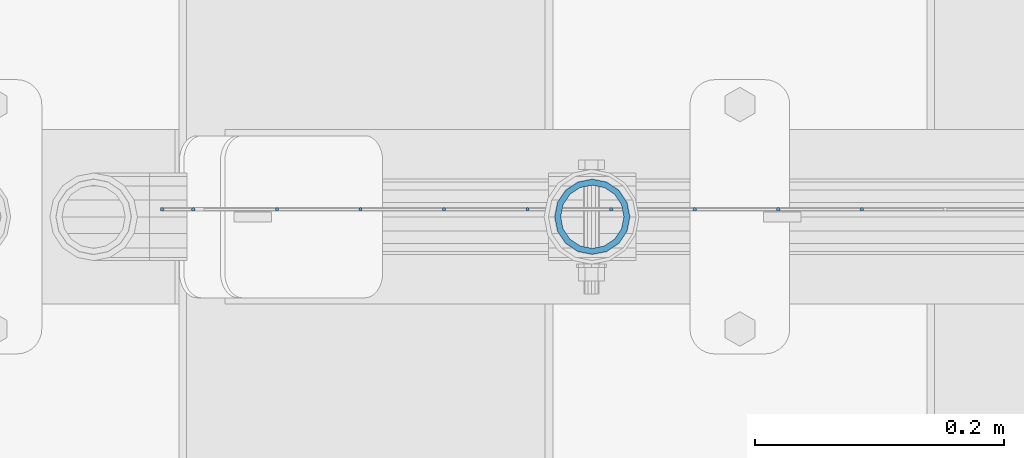
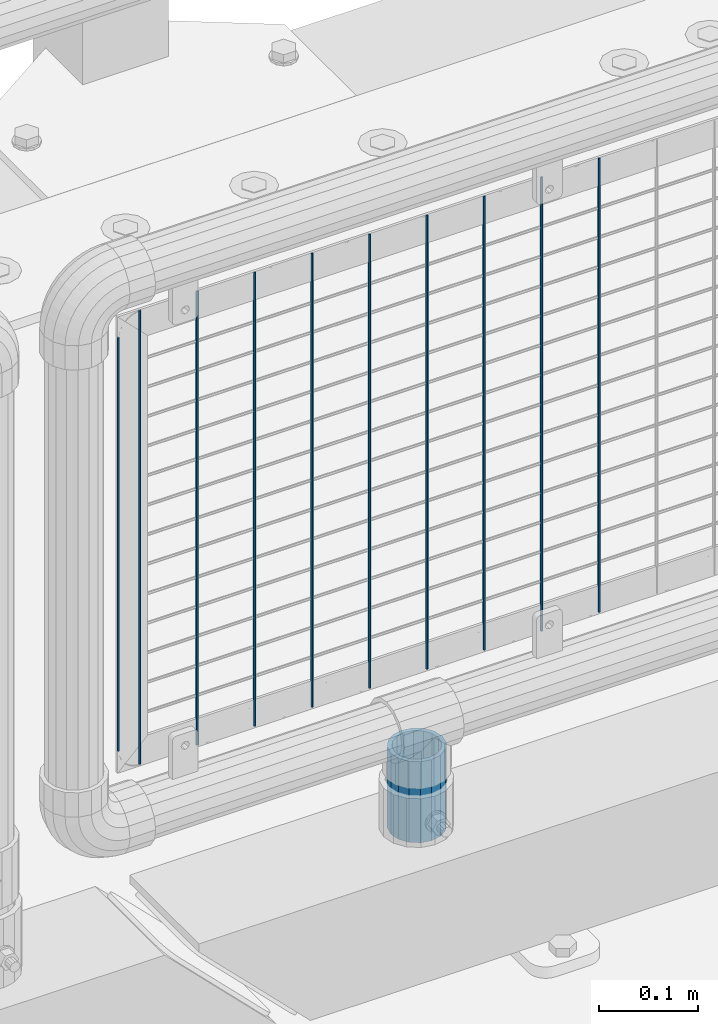
# One storey, part 94 of 240: 11 columns.
"""IFC2X3 building model written with IfcOpenShell, lengths in millimetres."""

from ifc_helpers import new_model, si_unit, frame, origin_with_axes, place, context, subcontext, project, spatial, faceted_brep, material, type_object, element, save


model = new_model("IFC2X3")

# Units and contexts
model_context = context("Model", 3, precision=1e-05, world=origin_with_axes())
body_context = subcontext(model_context, "Body", "Model", "MODEL_VIEW")
ifc_project = project(units=[si_unit("LENGTHUNIT", "METRE", prefix="MILLI"), si_unit("AREAUNIT", "SQUARE_METRE"), si_unit("VOLUMEUNIT", "CUBIC_METRE"), si_unit("MASSUNIT", "GRAM", prefix="KILO"), si_unit("TIMEUNIT", "SECOND"), si_unit("PLANEANGLEUNIT", "RADIAN"), si_unit("SOLIDANGLEUNIT", "STERADIAN"), si_unit("THERMODYNAMICTEMPERATUREUNIT", "DEGREE_CELSIUS"), si_unit("LUMINOUSINTENSITYUNIT", "LUMEN")], contexts=[model_context])

# Site, building, storey
site_placement = place(None, origin_with_axes())
site = spatial("IfcSite", under=ifc_project, at=site_placement, CompositionType="ELEMENT")
building_placement = place(site_placement, origin_with_axes())
building = spatial("IfcBuilding", under=site, at=building_placement, Name="Standard", CompositionType="ELEMENT")
storey_placement = place(building_placement, origin_with_axes())
storey = spatial("IfcBuildingStorey", under=building, at=storey_placement, Name="Undefined", CompositionType="ELEMENT", Elevation=0.0)

# Columns
ifc_material_1 = material()
column_type_1 = type_object("IfcColumnType", PredefinedType="NOTDEFINED")
column_1_placement = place(storey_placement, frame((55181.61, 34664.5, 168.02), z_axis=(-1.0, 0.0, 0.0), x_axis=(0.0, 0.0, 1.0)))
element("IfcColumn", 1, at=column_1_placement, inside=storey, type_object=column_type_1, material=ifc_material_1, context=body_context, shape_type="Brep", body=[
    faceted_brep([(0.0, -25.3499999999985, 0.0), (0.0, -23.4203461491634, 9.70102501045767), (100.0, -23.4203461491634, 9.70102501045767), (100.0, -25.3499999999985, 0.0), (0.0, -17.9251569030821, 17.9251569030821), (100.0, -17.9251569030821, 17.9251569030821), (0.0, -9.70102501045767, 23.4203461491634), (100.0, -9.70102501045767, 23.4203461491634), (0.0, 0.0, 25.3499999999985), (100.0, 0.0, 25.3499999999985), (0.0, 9.70102501045767, 23.4203461491634), (100.0, 9.70102501045767, 23.4203461491634), (0.0, 17.9251569030821, 17.9251569030821), (100.0, 17.9251569030821, 17.9251569030821), (0.0, 23.4203461491634, 9.70102501045767), (100.0, 23.4203461491634, 9.70102501045767), (0.0, 25.3499999999985, 0.0), (100.0, 25.3499999999985, 0.0), (0.0, 23.4203461491634, -9.70102501045767), (100.0, 23.4203461491634, -9.70102501045767), (0.0, 17.9251569030821, -17.9251569030821), (100.0, 17.9251569030821, -17.9251569030821), (0.0, 9.70102501045767, -23.4203461491634), (100.0, 9.70102501045767, -23.4203461491634), (0.0, 0.0, -25.3499999999985), (100.0, 0.0, -25.3499999999985), (0.0, -9.70102501045767, -23.4203461491634), (100.0, -9.70102501045767, -23.4203461491634), (0.0, -17.9251569030821, -17.9251569030821), (100.0, -17.9251569030821, -17.9251569030821), (0.0, -23.4203461491634, -9.70102501045767), (100.0, -23.4203461491634, -9.70102501045767), (0.0, -30.1500000000015, 0.0), (0.0, -27.8549679052157, -11.5379054858058), (100.0, -27.8549679052157, -11.5379054858058), (100.0, -30.1500000000015, 0.0), (0.0, -21.3192694527752, -21.3192694527752), (100.0, -21.3192694527752, -21.3192694527752), (0.0, -11.5379054858058, -27.8549679052157), (100.0, -11.5379054858058, -27.8549679052157), (0.0, 0.0, -30.1500000000015), (100.0, 0.0, -30.1500000000015), (0.0, 11.5379054858058, -27.8549679052157), (100.0, 11.5379054858058, -27.8549679052157), (0.0, 21.3192694527752, -21.3192694527752), (100.0, 21.3192694527752, -21.3192694527752), (0.0, 27.8549679052157, -11.5379054858058), (100.0, 27.8549679052157, -11.5379054858058), (0.0, 30.1500000000015, 0.0), (100.0, 30.1500000000015, 0.0), (0.0, 27.8549679052157, 11.5379054858058), (100.0, 27.8549679052157, 11.5379054858058), (0.0, 21.3192694527752, 21.3192694527752), (100.0, 21.3192694527752, 21.3192694527752), (0.0, 11.5379054858058, 27.8549679052157), (100.0, 11.5379054858058, 27.8549679052157), (0.0, 0.0, 30.1500000000015), (100.0, 0.0, 30.1500000000015), (0.0, -11.5379054858058, 27.8549679052157), (100.0, -11.5379054858058, 27.8549679052157), (0.0, -21.3192694527752, 21.3192694527752), (100.0, -21.3192694527752, 21.3192694527752), (0.0, -27.8549679052157, 11.5379054858058), (100.0, -27.8549679052157, 11.5379054858058)], [[[0, 1, 2, 3]], [[1, 4, 5, 2]], [[4, 6, 7, 5]], [[6, 8, 9, 7]], [[8, 10, 11, 9]], [[10, 12, 13, 11]], [[12, 14, 15, 13]], [[14, 16, 17, 15]], [[16, 18, 19, 17]], [[18, 20, 21, 19]], [[20, 22, 23, 21]], [[22, 24, 25, 23]], [[24, 26, 27, 25]], [[26, 28, 29, 27]], [[28, 30, 31, 29]], [[30, 0, 3, 31]], [[32, 33, 34, 35]], [[33, 36, 37, 34]], [[36, 38, 39, 37]], [[38, 40, 41, 39]], [[40, 42, 43, 41]], [[42, 44, 45, 43]], [[44, 46, 47, 45]], [[46, 48, 49, 47]], [[48, 50, 51, 49]], [[50, 52, 53, 51]], [[52, 54, 55, 53]], [[54, 56, 57, 55]], [[56, 58, 59, 57]], [[58, 60, 61, 59]], [[60, 62, 63, 61]], [[62, 32, 35, 63]], [[37, 39, 41, 43, 45, 47, 49, 51, 53, 55, 57, 59, 61, 63, 35, 34], [5, 7, 9, 11, 13, 15, 17, 19, 21, 23, 25, 27, 29, 31, 3, 2]], [[62, 60, 58, 56, 54, 52, 50, 48, 46, 44, 42, 40, 38, 36, 33, 32], [30, 28, 26, 24, 22, 20, 18, 16, 14, 12, 10, 8, 6, 4, 1, 0]]]),
])
ifc_material_2 = material(Name="Misc_Undefined")
column_type_2 = type_object("IfcColumnType", Name="D3", PredefinedType="NOTDEFINED")
for number, where, z_axis, x_axis in (
    (2, (55397.8340000001, 34670.4998693538, 353.02), (-1.0, 0.0, 0.0), (0.0, 0.0, 1.0)),
    (3, (55196.7500000001, 34670.4999119802, 353.02), (-1.0, 0.0, 0.0), (0.0, 0.0, 1.0)),
    (4, (55129.7220000001, 34670.499926189, 353.02), (-1.0, 0.0, 0.0), (0.0, 0.0, 1.0)),
    (5, (55062.6940000001, 34670.4999403979, 353.02), (-1.0, 0.0, 0.0), (0.0, 0.0, 1.0)),
    (6, (55263.7780000001, 34670.4998977714, 353.02), (-1.0, 0.0, 0.0), (0.0, 0.0, 1.0)),
    (7, (54995.666, 34670.4999546067, 353.02), (-1.0, 0.0, 0.0), (0.0, 0.0, 1.0)),
    (8, (55330.8060000001, 34670.4998835626, 353.02), (-1.0, 0.0, 0.0), (0.0, 0.0, 1.0)),
    (9, (54928.638, 34670.4999688155, 353.02), (-1.0, 0.0, 0.0), (0.0, 0.0, 1.0)),
):
    element("IfcColumn", number, at=place(storey_placement, frame(where, z_axis=z_axis, x_axis=x_axis)), inside=storey, type_object=column_type_2, material=ifc_material_2, ObjectType="D3", context=body_context, shape_type="Brep", body=[
        faceted_brep([(-7.27595761418343e-12, -1.49999999999272, 0.0), (-7.27595761418343e-12, -0.749999999992724, -1.29903810567669), (560.0, -0.75, -1.29903810567339), (560.0, -1.5, 0.0), (0.0, 0.750000000007276, -1.29903810567669), (560.0, 0.75, -1.29903810567339), (0.0, 1.50000000000728, 0.0), (560.0, 1.5, 0.0), (0.0, 0.750000000007276, 1.29903810567669), (560.0, 0.75, 1.29903810567339), (-7.27595761418343e-12, -0.749999999992724, 1.29903810567669), (560.0, -0.75, 1.29903810567339)], [[[0, 1, 2, 3]], [[1, 4, 5, 2]], [[4, 6, 7, 5]], [[6, 8, 9, 7]], [[8, 10, 11, 9]], [[10, 0, 3, 11]], [[5, 7, 9, 11, 3, 2]], [[10, 8, 6, 4, 1, 0]]]),
    ])
column_2_placement = place(storey_placement, frame((54836.61, 34670.4999883292, 378.02), z_axis=(-1.0, 0.0, 0.0), x_axis=(0.0, 0.0, 1.0)))
element("IfcColumn", 10, at=column_2_placement, inside=storey, type_object=column_type_2, material=ifc_material_2, ObjectType="D3", context=body_context, shape_type="Brep", body=[
    faceted_brep([(-7.27595761418343e-12, -1.49999999999272, 0.0), (-7.27595761418343e-12, -0.749999999992724, -1.29903810567669), (510.0, -0.75, -1.29903810567339), (510.0, -1.5, 0.0), (0.0, 0.750000000007276, -1.29903810567669), (510.0, 0.75, -1.29903810567339), (0.0, 1.50000000000728, 0.0), (510.0, 1.5, 0.0), (0.0, 0.750000000007276, 1.29903810567669), (510.0, 0.75, 1.29903810567339), (-7.27595761418343e-12, -0.749999999992724, 1.29903810567669), (510.0, -0.75, 1.29903810567339)], [[[0, 1, 2, 3]], [[1, 4, 5, 2]], [[4, 6, 7, 5]], [[6, 8, 9, 7]], [[8, 10, 11, 9]], [[10, 0, 3, 11]], [[5, 7, 9, 11, 3, 2]], [[10, 8, 6, 4, 1, 0]]]),
])
column_3_placement = place(storey_placement, frame((54861.61, 34670.4999830243, 353.02), z_axis=(-1.0, 0.0, 0.0), x_axis=(0.0, 0.0, 1.0)))
element("IfcColumn", 11, at=column_3_placement, inside=storey, type_object=column_type_2, material=ifc_material_2, ObjectType="D3", context=body_context, shape_type="Brep", body=[
    faceted_brep([(-7.27595761418343e-12, -1.49999999999272, 0.0), (-7.27595761418343e-12, -0.749999999992724, -1.29903810567669), (560.0, -0.75, -1.29903810567339), (560.0, -1.5, 0.0), (0.0, 0.750000000007276, -1.29903810567669), (560.0, 0.75, -1.29903810567339), (0.0, 1.50000000000728, 0.0), (560.0, 1.5, 0.0), (0.0, 0.750000000007276, 1.29903810567669), (560.0, 0.75, 1.29903810567339), (-7.27595761418343e-12, -0.749999999992724, 1.29903810567669), (560.0, -0.75, 1.29903810567339)], [[[0, 1, 2, 3]], [[1, 4, 5, 2]], [[4, 6, 7, 5]], [[6, 8, 9, 7]], [[8, 10, 11, 9]], [[10, 0, 3, 11]], [[5, 7, 9, 11, 3, 2]], [[10, 8, 6, 4, 1, 0]]]),
])

save(model, "model.ifc")
